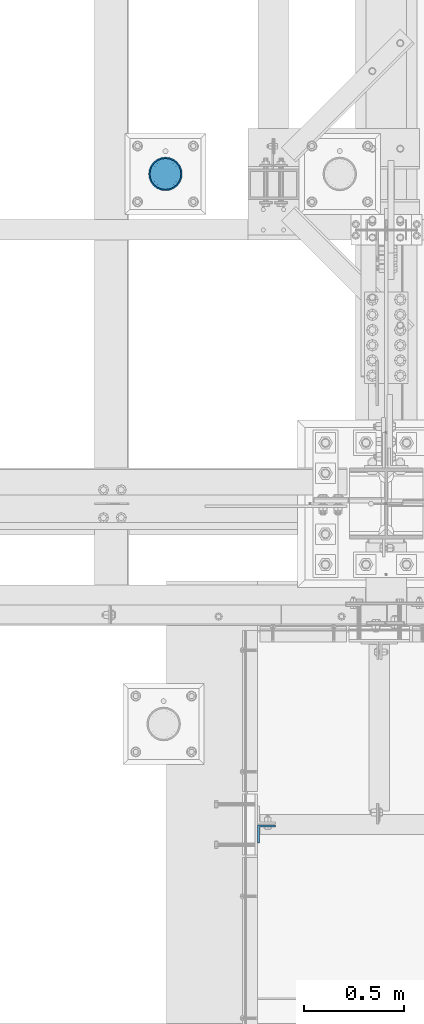
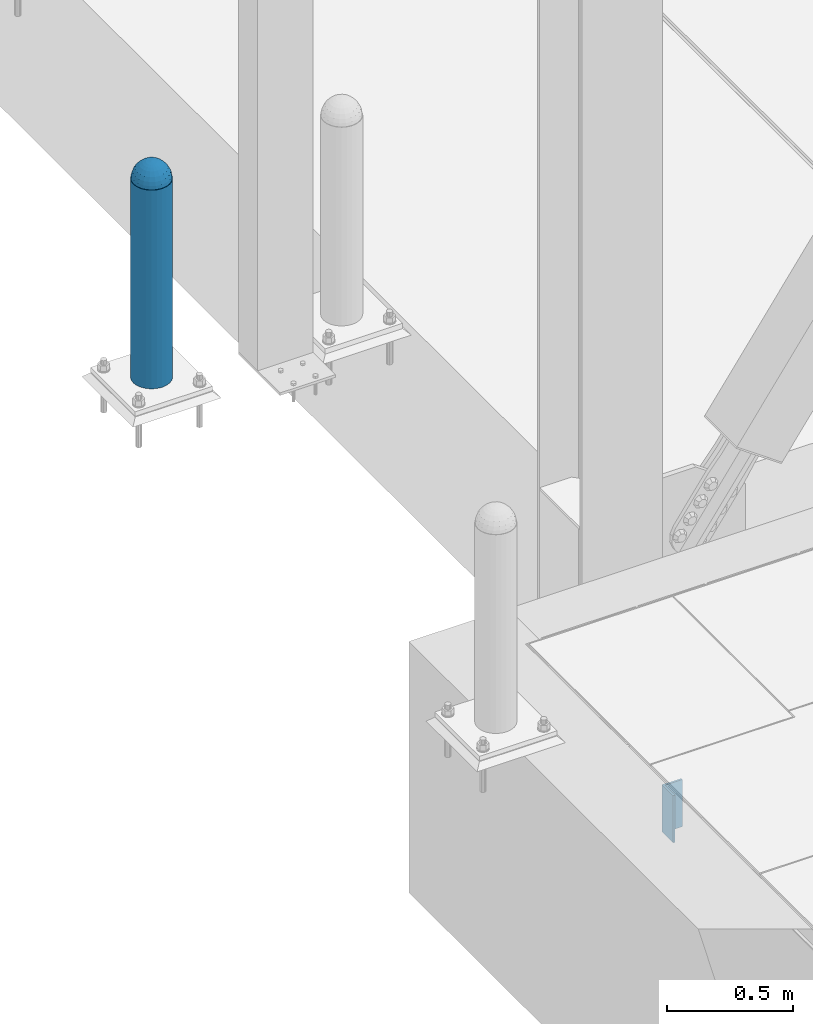
# One storey, part 1458 of 3843: 3 columns, 3 elements without a shape of their own.
"""IFC2X3 building model written with IfcOpenShell, lengths in millimetres."""

from ifc_helpers import new_model, si_unit, frame, origin_with_axes, place, context, subcontext, project, spatial, faceted_brep, material, type_object, element, aggregate, save


model = new_model("IFC2X3")

# Units and contexts
model_context = context("Model", 3, precision=1e-05, world=origin_with_axes())
body_context = subcontext(model_context, "Body", "Model", "MODEL_VIEW")
ifc_project = project(units=[si_unit("LENGTHUNIT", "METRE", prefix="MILLI"), si_unit("AREAUNIT", "SQUARE_METRE"), si_unit("VOLUMEUNIT", "CUBIC_METRE"), si_unit("MASSUNIT", "GRAM", prefix="KILO"), si_unit("TIMEUNIT", "SECOND"), si_unit("PLANEANGLEUNIT", "RADIAN"), si_unit("SOLIDANGLEUNIT", "STERADIAN"), si_unit("THERMODYNAMICTEMPERATUREUNIT", "DEGREE_CELSIUS"), si_unit("LUMINOUSINTENSITYUNIT", "LUMEN")], contexts=[model_context])

# Site, building, storey
site_placement = place(None, origin_with_axes())
site = spatial("IfcSite", under=ifc_project, at=site_placement, CompositionType="ELEMENT")
building_placement = place(site_placement, origin_with_axes())
building = spatial("IfcBuilding", under=site, at=building_placement, Name="Undefined", CompositionType="ELEMENT")
storey_placement = place(building_placement, origin_with_axes())
storey = spatial("IfcBuildingStorey", under=building, at=storey_placement, Name="Undefined", CompositionType="ELEMENT", Elevation=0.0)

# Assembly, column
assembly_1_placement = place(storey_placement, origin_with_axes())
assembly_1 = element("IfcElementAssembly", 1, at=assembly_1_placement, inside=storey, Name="CONC. FILL", AssemblyPlace="NOTDEFINED", PredefinedType="REINFORCEMENT_UNIT")
ifc_material_1 = material(Name="CONCRETE/1500")
column_type_1 = type_object("IfcColumnType", PredefinedType="NOTDEFINED")
column_1_placement = place(assembly_1_placement, frame((40956.2782592773, 27267.6153033043, 31411.8625), z_axis=(-1.0, 0.0, 0.0), x_axis=(0.0, 0.0, 1.0)))
column_1 = element("IfcColumn", 2, at=column_1_placement, type_object=column_type_1, material=ifc_material_1, Name="CONC. FILL", context=body_context, shape_type="Brep", body=[
    faceted_brep([(0.0, 0.0, 2.0), (0.0, -0.619999999995343, 1.89999999999964), (3.36549999999988, -7.1422259999963, 21.9814139999999), (3.36549999999988, 0.0, 23.1139999999996), (0.0, -1.17999999999302, 1.6200000000008), (3.36549999999988, -13.5910319999966, 18.6992260000006), (0.0, -1.61999999999534, 1.18000000000029), (3.36549999999988, -18.699225999997, 13.5910320000003), (0.0, -1.89999999999418, 0.6200000000008), (3.36549999999988, -21.9814139999944, 7.14222599999994), (0.0, -2.0, 0.0), (3.36549999999988, -23.1140000000014, 0.0), (0.0, -1.89999999999418, -0.6200000000008), (3.36549999999988, -21.9814139999944, -7.14222599999994), (0.0, -1.61999999999534, -1.18000000000029), (3.36549999999988, -18.699225999997, -13.5910320000003), (0.0, -1.17999999999302, -1.6200000000008), (3.36549999999988, -13.5910319999966, -18.6992260000006), (0.0, -0.619999999995343, -1.89999999999964), (3.36549999999988, -7.1422259999963, -21.9814139999999), (0.0, 0.0, -2.0), (3.36549999999988, 0.0, -23.1139999999996), (0.0, 0.619999999995343, -1.89999999999964), (3.36549999999988, 7.1422259999963, -21.9814139999999), (0.0, 1.17999999999302, -1.6200000000008), (3.36549999999988, 13.5910319999966, -18.6992260000006), (0.0, 1.61999999999534, -1.18000000000029), (3.36549999999988, 18.699225999997, -13.5910320000003), (0.0, 1.89999999999418, -0.6200000000008), (3.36549999999988, 21.9814139999944, -7.14222599999994), (0.0, 2.0, 0.0), (3.36549999999988, 23.1140000000014, 0.0), (0.0, 1.89999999999418, 0.6200000000008), (3.36549999999988, 21.9814139999944, 7.14222599999994), (0.0, 1.61999999999534, 1.18000000000029), (3.36549999999988, 18.699225999997, 13.5910320000003), (0.0, 1.17999999999302, 1.6200000000008), (3.36549999999988, 13.5910319999966, 18.6992260000006), (0.0, 0.619999999995343, 1.89999999999964), (3.36549999999988, 7.1422259999963, 21.9814139999999), (8.41374999999971, -11.1214661999984, 34.2282018000005), (8.41374999999971, 0.0, 35.9917999999998), (8.41374999999971, -21.1631784000056, 29.1173662000001), (8.41374999999971, -29.1173661999928, 21.1631784000001), (8.41374999999971, -34.2282017999969, 11.1214662000002), (8.41374999999971, -35.9918000000034, 0.0), (8.41374999999971, -34.2282017999969, -11.1214662000002), (8.41374999999971, -29.1173661999928, -21.1631784000001), (8.41374999999971, -21.1631784000056, -29.1173662000001), (8.41374999999971, -11.1214661999984, -34.2282018000005), (8.41374999999971, 0.0, -35.9917999999998), (8.41374999999971, 11.1214661999984, -34.2282018000005), (8.41374999999971, 21.1631784000056, -29.1173662000001), (8.41374999999971, 29.1173661999928, -21.1631784000001), (8.41374999999971, 34.2282017999969, -11.1214662000002), (8.41374999999971, 35.9918000000034, 0.0), (8.41374999999971, 34.2282017999969, 11.1214662000002), (8.41374999999971, 29.1173661999928, 21.1631784000001), (8.41374999999971, 21.1631784000056, 29.1173662000001), (8.41374999999971, 11.1214661999984, 34.2282018000005), (16.8274999999994, -15.3047700000025, 47.1030300000002), (16.8274999999994, 0.0, 49.5300000000007), (16.8274999999994, -29.1236400000053, 40.0697700000001), (16.8274999999994, -40.0697700000019, 29.1236399999998), (16.8274999999994, -47.1030299999984, 15.3047700000006), (16.8274999999994, -49.5299999999988, 0.0), (16.8274999999994, -47.1030299999984, -15.3047700000006), (16.8274999999994, -40.0697700000019, -29.1236399999998), (16.8274999999994, -29.1236400000053, -40.0697700000001), (16.8274999999994, -15.3047700000025, -47.1030300000002), (16.8274999999994, 0.0, -49.5300000000007), (16.8274999999994, 15.3047700000025, -47.1030300000002), (16.8274999999994, 29.1236400000053, -40.0697700000001), (16.8274999999994, 40.0697700000019, -29.1236399999998), (16.8274999999994, 47.1030299999984, -15.3047700000006), (16.8274999999994, 49.5299999999988, 0.0), (16.8274999999994, 47.1030299999984, 15.3047700000006), (16.8274999999994, 40.0697700000019, 29.1236399999998), (16.8274999999994, 29.1236400000053, 40.0697700000001), (16.8274999999994, 15.3047700000025, 47.1030300000002), (33.6549999999988, -20.4063599999936, 62.8040400000009), (33.6549999999988, 0.0, 66.0400000000009), (33.6549999999988, -38.831520000007, 53.4263599999995), (33.6549999999988, -53.4263599999977, 38.8315199999997), (33.6549999999988, -62.8040400000027, 20.4063600000009), (33.6549999999988, -66.0399999999936, 0.0), (33.6549999999988, -62.8040400000027, -20.4063600000009), (33.6549999999988, -53.4263599999977, -38.8315199999997), (33.6549999999988, -38.831520000007, -53.4263599999995), (33.6549999999988, -20.4063599999936, -62.8040400000009), (33.6549999999988, 0.0, -66.0400000000009), (33.6549999999988, 20.4063599999936, -62.8040400000009), (33.6549999999988, 38.831520000007, -53.4263599999995), (33.6549999999988, 53.4263599999977, -38.8315199999997), (33.6549999999988, 62.8040400000027, -20.4063600000009), (33.6549999999988, 66.0399999999936, 0.0), (33.6549999999988, 62.8040400000027, 20.4063600000009), (33.6549999999988, 53.4263599999977, 38.8315199999997), (33.6549999999988, 38.831520000007, 53.4263599999995), (33.6549999999988, 20.4063599999936, 62.8040400000009), (50.4824999999983, -23.3907901500061, 71.9891308499991), (50.4824999999983, 0.0, 75.6983500000006), (50.4824999999983, -44.5106298000028, 61.23996515), (50.4824999999983, -61.2399651500018, 44.5106297999992), (50.4824999999983, -71.9891308499937, 23.3907901500006), (50.4824999999983, -75.698350000006, 0.0), (50.4824999999983, -71.9891308499937, -23.3907901500006), (50.4824999999983, -61.2399651500018, -44.5106297999992), (50.4824999999983, -44.5106298000028, -61.23996515), (50.4824999999983, -23.3907901500061, -71.9891308499991), (50.4824999999983, 0.0, -75.6983500000006), (50.4824999999983, 23.3907901500061, -71.9891308499991), (50.4824999999983, 44.5106298000028, -61.23996515), (50.4824999999983, 61.2399651500018, -44.5106297999992), (50.4824999999983, 71.9891308499937, -23.3907901500006), (50.4824999999983, 75.698350000006, 0.0), (50.4824999999983, 71.9891308499937, 23.3907901500006), (50.4824999999983, 61.2399651500018, 44.5106297999992), (50.4824999999983, 44.5106298000028, 61.23996515), (50.4824999999983, 23.3907901500061, 71.9891308499991), (67.3099999999977, -24.9977910000016, 76.9349490000004), (67.3099999999977, 0.0, 80.8989999999994), (67.3099999999977, -47.5686120000028, 65.4472910000004), (67.3099999999977, -65.447291000004, 47.5686119999991), (67.3099999999977, -76.9349490000022, 24.9977909999998), (67.3099999999977, -80.8990000000049, 0.0), (67.3099999999977, -76.9349490000022, -24.9977909999998), (67.3099999999977, -65.447291000004, -47.5686119999991), (67.3099999999977, -47.5686120000028, -65.4472910000004), (67.3099999999977, -24.9977910000016, -76.9349490000004), (67.3099999999977, 0.0, -80.8989999999994), (67.3099999999977, 24.9977910000016, -76.9349490000004), (67.3099999999977, 47.5686120000028, -65.4472910000004), (67.3099999999977, 65.447291000004, -47.5686119999991), (67.3099999999977, 76.9349490000022, -24.9977909999998), (67.3099999999977, 80.8990000000049, 0.0), (67.3099999999977, 76.9349490000022, 24.9977909999998), (67.3099999999977, 65.447291000004, 47.5686119999991), (67.3099999999977, 47.5686120000028, 65.4472910000004), (67.3099999999977, 24.9977910000016, 76.9349490000004), (84.1374999999935, -25.5079499999993, 78.5050499999998), (84.1374999999935, 0.0, 82.5499999999993), (84.1374999999935, -48.5393999999942, 66.7829500000007), (84.1374999999935, -66.7829499999934, 48.5393999999997), (84.1374999999935, -78.505050000007, 25.5079499999993), (84.1374999999935, -82.5500000000029, 0.0), (84.1374999999935, -78.505050000007, -25.5079499999993), (84.1374999999935, -66.7829499999934, -48.5393999999997), (84.1374999999935, -48.5393999999942, -66.7829500000007), (84.1374999999935, -25.5079499999993, -78.5050499999998), (84.1374999999935, 0.0, -82.5499999999993), (84.1374999999935, 25.5079499999993, -78.5050499999998), (84.1374999999935, 48.5393999999942, -66.7829500000007), (84.1374999999935, 66.7829499999934, -48.5393999999997), (84.1374999999935, 78.505050000007, -25.5079499999993), (84.1374999999935, 82.5500000000029, 0.0), (84.1374999999935, 78.505050000007, 25.5079499999993), (84.1374999999935, 66.7829499999934, 48.5393999999997), (84.1374999999935, 48.5393999999942, 66.7829500000007), (84.1374999999935, 25.5079499999993, 78.5050499999998), (100.964999999993, -24.9977910000016, 76.9349490000004), (100.964999999993, 0.0, 80.8989999999994), (100.964999999993, -47.5686120000028, 65.4472910000004), (100.964999999993, -65.447291000004, 47.5686119999991), (100.964999999993, -76.9349490000022, 24.9977909999998), (100.964999999993, -80.8990000000049, 0.0), (100.964999999993, -76.9349490000022, -24.9977909999998), (100.964999999993, -65.447291000004, -47.5686119999991), (100.964999999993, -47.5686120000028, -65.4472910000004), (100.964999999993, -24.9977910000016, -76.9349490000004), (100.964999999993, 0.0, -80.8989999999994), (100.964999999993, 24.9977910000016, -76.9349490000004), (100.964999999993, 47.5686120000028, -65.4472910000004), (100.964999999993, 65.447291000004, -47.5686119999991), (100.964999999993, 76.9349490000022, -24.9977909999998), (100.964999999993, 80.8990000000049, 0.0), (100.964999999993, 76.9349490000022, 24.9977909999998), (100.964999999993, 65.447291000004, 47.5686119999991), (100.964999999993, 47.5686120000028, 65.4472910000004), (100.964999999993, 24.9977910000016, 76.9349490000004), (117.792499999992, -23.3907901500061, 71.9891308499991), (117.792499999992, 0.0, 75.6983500000006), (117.792499999992, -44.5106298000028, 61.23996515), (117.792499999992, -61.2399651500018, 44.5106297999992), (117.792499999992, -71.9891308499937, 23.3907901500006), (117.792499999992, -75.698350000006, 0.0), (117.792499999992, -71.9891308499937, -23.3907901500006), (117.792499999992, -61.2399651500018, -44.5106297999992), (117.792499999992, -44.5106298000028, -61.23996515), (117.792499999992, -23.3907901500061, -71.9891308499991), (117.792499999992, 0.0, -75.6983500000006), (117.792499999992, 23.3907901500061, -71.9891308499991), (117.792499999992, 44.5106298000028, -61.23996515), (117.792499999992, 61.2399651500018, -44.5106297999992), (117.792499999992, 71.9891308499937, -23.3907901500006), (117.792499999992, 75.698350000006, 0.0), (117.792499999992, 71.9891308499937, 23.3907901500006), (117.792499999992, 61.2399651500018, 44.5106297999992), (117.792499999992, 44.5106298000028, 61.23996515), (117.792499999992, 23.3907901500061, 71.9891308499991), (134.619999999992, -20.4063599999936, 62.8040400000009), (134.619999999992, 0.0, 66.0400000000009), (134.619999999992, -38.831520000007, 53.4263599999995), (134.619999999992, -53.4263599999977, 38.8315199999997), (134.619999999992, -62.8040400000027, 20.4063600000009), (134.619999999992, -66.0399999999936, 0.0), (134.619999999992, -62.8040400000027, -20.4063600000009), (134.619999999992, -53.4263599999977, -38.8315199999997), (134.619999999992, -38.831520000007, -53.4263599999995), (134.619999999992, -20.4063599999936, -62.8040400000009), (134.619999999992, 0.0, -66.0400000000009), (134.619999999992, 20.4063599999936, -62.8040400000009), (134.619999999992, 38.831520000007, -53.4263599999995), (134.619999999992, 53.4263599999977, -38.8315199999997), (134.619999999992, 62.8040400000027, -20.4063600000009), (134.619999999992, 66.0399999999936, 0.0), (134.619999999992, 62.8040400000027, 20.4063600000009), (134.619999999992, 53.4263599999977, 38.8315199999997), (134.619999999992, 38.831520000007, 53.4263599999995), (134.619999999992, 20.4063599999936, 62.8040400000009), (151.447499999991, -15.3047700000025, 47.1030300000002), (151.447499999991, 0.0, 49.5300000000007), (151.447499999991, -29.1236400000053, 40.0697700000001), (151.447499999991, -40.0697700000019, 29.1236399999998), (151.447499999991, -47.1030299999984, 15.3047700000006), (151.447499999991, -49.5299999999988, 0.0), (151.447499999991, -47.1030299999984, -15.3047700000006), (151.447499999991, -40.0697700000019, -29.1236399999998), (151.447499999991, -29.1236400000053, -40.0697700000001), (151.447499999991, -15.3047700000025, -47.1030300000002), (151.447499999991, 0.0, -49.5300000000007), (151.447499999991, 15.3047700000025, -47.1030300000002), (151.447499999991, 29.1236400000053, -40.0697700000001), (151.447499999991, 40.0697700000019, -29.1236399999998), (151.447499999991, 47.1030299999984, -15.3047700000006), (151.447499999991, 49.5299999999988, 0.0), (151.447499999991, 47.1030299999984, 15.3047700000006), (151.447499999991, 40.0697700000019, 29.1236399999998), (151.447499999991, 29.1236400000053, 40.0697700000001), (151.447499999991, 15.3047700000025, 47.1030300000002), (159.861249999991, -11.1214661999984, 34.2282018000005), (159.861249999991, 0.0, 35.9917999999998), (159.861249999991, -21.1631784000056, 29.1173662000001), (159.861249999991, -29.1173661999928, 21.1631784000001), (159.861249999991, -34.2282017999969, 11.1214662000002), (159.861249999991, -35.9918000000034, 0.0), (159.861249999991, -34.2282017999969, -11.1214662000002), (159.861249999991, -29.1173661999928, -21.1631784000001), (159.861249999991, -21.1631784000056, -29.1173662000001), (159.861249999991, -11.1214661999984, -34.2282018000005), (159.861249999991, 0.0, -35.9917999999998), (159.861249999991, 11.1214661999984, -34.2282018000005), (159.861249999991, 21.1631784000056, -29.1173662000001), (159.861249999991, 29.1173661999928, -21.1631784000001), (159.861249999991, 34.2282017999969, -11.1214662000002), (159.861249999991, 35.9918000000034, 0.0), (159.861249999991, 34.2282017999969, 11.1214662000002), (159.861249999991, 29.1173661999928, 21.1631784000001), (159.861249999991, 21.1631784000056, 29.1173662000001), (159.861249999991, 11.1214661999984, 34.2282018000005), (164.909499999991, -7.1422259999963, 21.9814139999999), (164.909499999991, 0.0, 23.1139999999996), (164.909499999991, -13.5910319999966, 18.6992260000006), (164.909499999991, -18.699225999997, 13.5910320000003), (164.909499999991, -21.9814139999944, 7.14222599999994), (164.909499999991, -23.1140000000014, 0.0), (164.909499999991, -21.9814139999944, -7.14222599999994), (164.909499999991, -18.699225999997, -13.5910320000003), (164.909499999991, -13.5910319999966, -18.6992260000006), (164.909499999991, -7.1422259999963, -21.9814139999999), (164.909499999991, 0.0, -23.1139999999996), (164.909499999991, 7.1422259999963, -21.9814139999999), (164.909499999991, 13.5910319999966, -18.6992260000006), (164.909499999991, 18.699225999997, -13.5910320000003), (164.909499999991, 21.9814139999944, -7.14222599999994), (164.909499999991, 23.1140000000014, 0.0), (164.909499999991, 21.9814139999944, 7.14222599999994), (164.909499999991, 18.699225999997, 13.5910320000003), (164.909499999991, 13.5910319999966, 18.6992260000006), (164.909499999991, 7.1422259999963, 21.9814139999999), (168.274999999991, -0.619999999995343, 1.89999999999964), (168.274999999991, 0.0, 2.0), (168.274999999991, -1.17999999999302, 1.6200000000008), (168.274999999991, -1.61999999999534, 1.18000000000029), (168.274999999991, -1.89999999999418, 0.6200000000008), (168.274999999991, -2.0, 0.0), (168.274999999991, -1.89999999999418, -0.6200000000008), (168.274999999991, -1.61999999999534, -1.18000000000029), (168.274999999991, -1.17999999999302, -1.6200000000008), (168.274999999991, -0.619999999995343, -1.89999999999964), (168.274999999991, 0.0, -2.0), (168.274999999991, 0.619999999995343, -1.89999999999964), (168.274999999991, 1.17999999999302, -1.6200000000008), (168.274999999991, 1.61999999999534, -1.18000000000029), (168.274999999991, 1.89999999999418, -0.6200000000008), (168.274999999991, 2.0, 0.0), (168.274999999991, 1.89999999999418, 0.6200000000008), (168.274999999991, 1.61999999999534, 1.18000000000029), (168.274999999991, 1.17999999999302, 1.6200000000008), (168.274999999991, 0.619999999995343, 1.89999999999964)], [[[0, 1, 2, 3]], [[1, 4, 5, 2]], [[4, 6, 7, 5]], [[6, 8, 9, 7]], [[8, 10, 11, 9]], [[10, 12, 13, 11]], [[12, 14, 15, 13]], [[14, 16, 17, 15]], [[16, 18, 19, 17]], [[18, 20, 21, 19]], [[20, 22, 23, 21]], [[22, 24, 25, 23]], [[24, 26, 27, 25]], [[26, 28, 29, 27]], [[28, 30, 31, 29]], [[30, 32, 33, 31]], [[32, 34, 35, 33]], [[34, 36, 37, 35]], [[36, 38, 39, 37]], [[38, 0, 3, 39]], [[38, 36, 34, 32, 30, 28, 26, 24, 22, 20, 18, 16, 14, 12, 10, 8, 6, 4, 1, 0]], [[3, 2, 40, 41]], [[2, 5, 42, 40]], [[5, 7, 43, 42]], [[7, 9, 44, 43]], [[9, 11, 45, 44]], [[11, 13, 46, 45]], [[13, 15, 47, 46]], [[15, 17, 48, 47]], [[17, 19, 49, 48]], [[19, 21, 50, 49]], [[21, 23, 51, 50]], [[23, 25, 52, 51]], [[25, 27, 53, 52]], [[27, 29, 54, 53]], [[29, 31, 55, 54]], [[31, 33, 56, 55]], [[33, 35, 57, 56]], [[35, 37, 58, 57]], [[37, 39, 59, 58]], [[39, 3, 41, 59]], [[41, 40, 60, 61]], [[40, 42, 62, 60]], [[42, 43, 63, 62]], [[43, 44, 64, 63]], [[44, 45, 65, 64]], [[45, 46, 66, 65]], [[46, 47, 67, 66]], [[47, 48, 68, 67]], [[48, 49, 69, 68]], [[49, 50, 70, 69]], [[50, 51, 71, 70]], [[51, 52, 72, 71]], [[52, 53, 73, 72]], [[53, 54, 74, 73]], [[54, 55, 75, 74]], [[55, 56, 76, 75]], [[56, 57, 77, 76]], [[57, 58, 78, 77]], [[58, 59, 79, 78]], [[59, 41, 61, 79]], [[61, 60, 80, 81]], [[60, 62, 82, 80]], [[62, 63, 83, 82]], [[63, 64, 84, 83]], [[64, 65, 85, 84]], [[65, 66, 86, 85]], [[66, 67, 87, 86]], [[67, 68, 88, 87]], [[68, 69, 89, 88]], [[69, 70, 90, 89]], [[70, 71, 91, 90]], [[71, 72, 92, 91]], [[72, 73, 93, 92]], [[73, 74, 94, 93]], [[74, 75, 95, 94]], [[75, 76, 96, 95]], [[76, 77, 97, 96]], [[77, 78, 98, 97]], [[78, 79, 99, 98]], [[79, 61, 81, 99]], [[81, 80, 100, 101]], [[80, 82, 102, 100]], [[82, 83, 103, 102]], [[83, 84, 104, 103]], [[84, 85, 105, 104]], [[85, 86, 106, 105]], [[86, 87, 107, 106]], [[87, 88, 108, 107]], [[88, 89, 109, 108]], [[89, 90, 110, 109]], [[90, 91, 111, 110]], [[91, 92, 112, 111]], [[92, 93, 113, 112]], [[93, 94, 114, 113]], [[94, 95, 115, 114]], [[95, 96, 116, 115]], [[96, 97, 117, 116]], [[97, 98, 118, 117]], [[98, 99, 119, 118]], [[99, 81, 101, 119]], [[101, 100, 120, 121]], [[100, 102, 122, 120]], [[102, 103, 123, 122]], [[103, 104, 124, 123]], [[104, 105, 125, 124]], [[105, 106, 126, 125]], [[106, 107, 127, 126]], [[107, 108, 128, 127]], [[108, 109, 129, 128]], [[109, 110, 130, 129]], [[110, 111, 131, 130]], [[111, 112, 132, 131]], [[112, 113, 133, 132]], [[113, 114, 134, 133]], [[114, 115, 135, 134]], [[115, 116, 136, 135]], [[116, 117, 137, 136]], [[117, 118, 138, 137]], [[118, 119, 139, 138]], [[119, 101, 121, 139]], [[121, 120, 140, 141]], [[120, 122, 142, 140]], [[122, 123, 143, 142]], [[123, 124, 144, 143]], [[124, 125, 145, 144]], [[125, 126, 146, 145]], [[126, 127, 147, 146]], [[127, 128, 148, 147]], [[128, 129, 149, 148]], [[129, 130, 150, 149]], [[130, 131, 151, 150]], [[131, 132, 152, 151]], [[132, 133, 153, 152]], [[133, 134, 154, 153]], [[134, 135, 155, 154]], [[135, 136, 156, 155]], [[136, 137, 157, 156]], [[137, 138, 158, 157]], [[138, 139, 159, 158]], [[139, 121, 141, 159]], [[141, 140, 160, 161]], [[140, 142, 162, 160]], [[142, 143, 163, 162]], [[143, 144, 164, 163]], [[144, 145, 165, 164]], [[145, 146, 166, 165]], [[146, 147, 167, 166]], [[147, 148, 168, 167]], [[148, 149, 169, 168]], [[149, 150, 170, 169]], [[150, 151, 171, 170]], [[151, 152, 172, 171]], [[152, 153, 173, 172]], [[153, 154, 174, 173]], [[154, 155, 175, 174]], [[155, 156, 176, 175]], [[156, 157, 177, 176]], [[157, 158, 178, 177]], [[158, 159, 179, 178]], [[159, 141, 161, 179]], [[161, 160, 180, 181]], [[160, 162, 182, 180]], [[162, 163, 183, 182]], [[163, 164, 184, 183]], [[164, 165, 185, 184]], [[165, 166, 186, 185]], [[166, 167, 187, 186]], [[167, 168, 188, 187]], [[168, 169, 189, 188]], [[169, 170, 190, 189]], [[170, 171, 191, 190]], [[171, 172, 192, 191]], [[172, 173, 193, 192]], [[173, 174, 194, 193]], [[174, 175, 195, 194]], [[175, 176, 196, 195]], [[176, 177, 197, 196]], [[177, 178, 198, 197]], [[178, 179, 199, 198]], [[179, 161, 181, 199]], [[181, 180, 200, 201]], [[180, 182, 202, 200]], [[182, 183, 203, 202]], [[183, 184, 204, 203]], [[184, 185, 205, 204]], [[185, 186, 206, 205]], [[186, 187, 207, 206]], [[187, 188, 208, 207]], [[188, 189, 209, 208]], [[189, 190, 210, 209]], [[190, 191, 211, 210]], [[191, 192, 212, 211]], [[192, 193, 213, 212]], [[193, 194, 214, 213]], [[194, 195, 215, 214]], [[195, 196, 216, 215]], [[196, 197, 217, 216]], [[197, 198, 218, 217]], [[198, 199, 219, 218]], [[199, 181, 201, 219]], [[201, 200, 220, 221]], [[200, 202, 222, 220]], [[202, 203, 223, 222]], [[203, 204, 224, 223]], [[204, 205, 225, 224]], [[205, 206, 226, 225]], [[206, 207, 227, 226]], [[207, 208, 228, 227]], [[208, 209, 229, 228]], [[209, 210, 230, 229]], [[210, 211, 231, 230]], [[211, 212, 232, 231]], [[212, 213, 233, 232]], [[213, 214, 234, 233]], [[214, 215, 235, 234]], [[215, 216, 236, 235]], [[216, 217, 237, 236]], [[217, 218, 238, 237]], [[218, 219, 239, 238]], [[219, 201, 221, 239]], [[221, 220, 240, 241]], [[220, 222, 242, 240]], [[222, 223, 243, 242]], [[223, 224, 244, 243]], [[224, 225, 245, 244]], [[225, 226, 246, 245]], [[226, 227, 247, 246]], [[227, 228, 248, 247]], [[228, 229, 249, 248]], [[229, 230, 250, 249]], [[230, 231, 251, 250]], [[231, 232, 252, 251]], [[232, 233, 253, 252]], [[233, 234, 254, 253]], [[234, 235, 255, 254]], [[235, 236, 256, 255]], [[236, 237, 257, 256]], [[237, 238, 258, 257]], [[238, 239, 259, 258]], [[239, 221, 241, 259]], [[241, 240, 260, 261]], [[240, 242, 262, 260]], [[242, 243, 263, 262]], [[243, 244, 264, 263]], [[244, 245, 265, 264]], [[245, 246, 266, 265]], [[246, 247, 267, 266]], [[247, 248, 268, 267]], [[248, 249, 269, 268]], [[249, 250, 270, 269]], [[250, 251, 271, 270]], [[251, 252, 272, 271]], [[252, 253, 273, 272]], [[253, 254, 274, 273]], [[254, 255, 275, 274]], [[255, 256, 276, 275]], [[256, 257, 277, 276]], [[257, 258, 278, 277]], [[258, 259, 279, 278]], [[259, 241, 261, 279]], [[261, 260, 280, 281]], [[260, 262, 282, 280]], [[262, 263, 283, 282]], [[263, 264, 284, 283]], [[264, 265, 285, 284]], [[265, 266, 286, 285]], [[266, 267, 287, 286]], [[267, 268, 288, 287]], [[268, 269, 289, 288]], [[269, 270, 290, 289]], [[270, 271, 291, 290]], [[271, 272, 292, 291]], [[272, 273, 293, 292]], [[273, 274, 294, 293]], [[274, 275, 295, 294]], [[275, 276, 296, 295]], [[276, 277, 297, 296]], [[277, 278, 298, 297]], [[278, 279, 299, 298]], [[279, 261, 281, 299]], [[282, 283, 284, 285, 286, 287, 288, 289, 290, 291, 292, 293, 294, 295, 296, 297, 298, 299, 281, 280]]]),
])
aggregate(assembly_1, [column_1])

assembly_2_placement = place(storey_placement, origin_with_axes())
assembly_2 = element("IfcElementAssembly", 3, at=assembly_2_placement, inside=storey, Name="PIPE_BOLLARD", AssemblyPlace="NOTDEFINED", PredefinedType="RIGID_FRAME")
ifc_material_2 = material()
column_type_2 = type_object("IfcColumnType", Name="PIPE6SCH40", PredefinedType="NOTDEFINED")
column_2_placement = place(assembly_2_placement, frame((40956.2782592774, 27267.6153033043, 30480.0), z_axis=(-1.0, 0.0, 0.0), x_axis=(0.0, 0.0, 1.0)))
column_2 = element("IfcColumn", 4, at=column_2_placement, type_object=column_type_2, material=ifc_material_2, Name="PIPE_BOLLARD", ObjectType="PIPE6SCH40", context=body_context, shape_type="Brep", body=[
    faceted_brep([(50.7999999999993, -77.0890000000072, 0.0), (50.7999999999993, -74.4622560228017, 19.9521013679114), (1016.0, -74.4622560228017, 19.9521013679114), (1016.0, -77.0890000000072, 0.0), (50.7999999999993, -66.7610323523404, 38.5445000000036), (1016.0, -66.7610323523404, 38.5445000000036), (50.7999999999993, -54.5101546548831, 54.5101546548904), (1016.0, -54.5101546548831, 54.5101546548904), (50.7999999999993, -38.5445000000036, 66.7610323523404), (1016.0, -38.5445000000036, 66.7610323523404), (50.7999999999993, -19.9521013679041, 74.4622560227945), (1016.0, -19.9521013679041, 74.4622560227945), (50.7999999999993, 0.0, 77.0889999999999), (1016.0, 0.0, 77.0889999999999), (50.7999999999993, 19.9521013679041, 74.4622560227945), (1016.0, 19.9521013679041, 74.4622560227945), (50.7999999999993, 38.5445000000036, 66.7610323523404), (1016.0, 38.5445000000036, 66.7610323523404), (50.7999999999993, 54.5101546548831, 54.5101546548904), (1016.0, 54.5101546548831, 54.5101546548904), (50.7999999999993, 66.7610323523404, 38.5445000000036), (1016.0, 66.7610323523404, 38.5445000000036), (50.7999999999993, 74.4622560228017, 19.9521013679114), (1016.0, 74.4622560228017, 19.9521013679114), (50.7999999999993, 77.0890000000072, 0.0), (1016.0, 77.0890000000072, 0.0), (50.7999999999993, 74.4622560228017, -19.9521013679114), (1016.0, 74.4622560228017, -19.9521013679114), (50.7999999999993, 66.7610323523404, -38.5445000000036), (1016.0, 66.7610323523404, -38.5445000000036), (50.7999999999993, 54.5101546548831, -54.5101546548904), (1016.0, 54.5101546548831, -54.5101546548904), (50.7999999999993, 38.5445000000036, -66.7610323523404), (1016.0, 38.5445000000036, -66.7610323523404), (50.7999999999993, 19.9521013679041, -74.4622560227945), (1016.0, 19.9521013679041, -74.4622560227945), (50.7999999999993, 0.0, -77.0889999999999), (1016.0, 0.0, -77.0889999999999), (50.7999999999993, -19.9521013679041, -74.4622560227945), (1016.0, -19.9521013679041, -74.4622560227945), (50.7999999999993, -38.5445000000036, -66.7610323523404), (1016.0, -38.5445000000036, -66.7610323523404), (50.7999999999993, -54.5101546548831, -54.5101546548904), (1016.0, -54.5101546548831, -54.5101546548904), (50.7999999999993, -66.7610323523404, -38.5445000000036), (1016.0, -66.7610323523404, -38.5445000000036), (50.7999999999993, -74.4622560228017, -19.9521013679114), (1016.0, -74.4622560228017, -19.9521013679114), (50.7999999999993, -84.2010000000009, 0.0), (50.7999999999993, -81.3319204993604, -21.7928224166753), (1016.0, -81.3319204993604, -21.7928224166753), (1016.0, -84.2010000000009, 0.0), (50.7999999999993, -72.9202050240565, -42.1005000000005), (1016.0, -72.9202050240565, -42.1005000000005), (50.7999999999993, -59.5390980826924, -59.5390980826851), (1016.0, -59.5390980826924, -59.5390980826851), (50.7999999999993, -42.1005000000005, -72.9202050240565), (1016.0, -42.1005000000005, -72.9202050240565), (50.7999999999993, -21.7928224166826, -81.3319204993677), (1016.0, -21.7928224166826, -81.3319204993677), (50.7999999999993, 0.0, -84.2010000000009), (1016.0, 0.0, -84.2010000000009), (50.7999999999993, 21.7928224166826, -81.3319204993677), (1016.0, 21.7928224166826, -81.3319204993677), (50.7999999999993, 42.1005000000005, -72.9202050240565), (1016.0, 42.1005000000005, -72.9202050240565), (50.7999999999993, 59.5390980826924, -59.5390980826851), (1016.0, 59.5390980826924, -59.5390980826851), (50.7999999999993, 72.9202050240565, -42.1005000000005), (1016.0, 72.9202050240565, -42.1005000000005), (50.7999999999993, 81.3319204993604, -21.7928224166753), (1016.0, 81.3319204993604, -21.7928224166753), (50.7999999999993, 84.2010000000009, 0.0), (1016.0, 84.2010000000009, 0.0), (50.7999999999993, 81.3319204993604, 21.7928224166753), (1016.0, 81.3319204993604, 21.7928224166753), (50.7999999999993, 72.9202050240565, 42.1005000000005), (1016.0, 72.9202050240565, 42.1005000000005), (50.7999999999993, 59.5390980826924, 59.5390980826851), (1016.0, 59.5390980826924, 59.5390980826851), (50.7999999999993, 42.1005000000005, 72.9202050240565), (1016.0, 42.1005000000005, 72.9202050240565), (50.7999999999993, 21.7928224166826, 81.3319204993677), (1016.0, 21.7928224166826, 81.3319204993677), (50.7999999999993, 0.0, 84.2010000000009), (1016.0, 0.0, 84.2010000000009), (50.7999999999993, -21.7928224166826, 81.3319204993677), (1016.0, -21.7928224166826, 81.3319204993677), (50.7999999999993, -42.1005000000005, 72.9202050240565), (1016.0, -42.1005000000005, 72.9202050240565), (50.7999999999993, -59.5390980826924, 59.5390980826851), (1016.0, -59.5390980826924, 59.5390980826851), (50.7999999999993, -72.9202050240565, 42.1005000000005), (1016.0, -72.9202050240565, 42.1005000000005), (50.7999999999993, -81.3319204993604, 21.7928224166753), (1016.0, -81.3319204993604, 21.7928224166753)], [[[0, 1, 2, 3]], [[1, 4, 5, 2]], [[4, 6, 7, 5]], [[6, 8, 9, 7]], [[8, 10, 11, 9]], [[10, 12, 13, 11]], [[12, 14, 15, 13]], [[14, 16, 17, 15]], [[16, 18, 19, 17]], [[18, 20, 21, 19]], [[20, 22, 23, 21]], [[22, 24, 25, 23]], [[24, 26, 27, 25]], [[26, 28, 29, 27]], [[28, 30, 31, 29]], [[30, 32, 33, 31]], [[32, 34, 35, 33]], [[34, 36, 37, 35]], [[36, 38, 39, 37]], [[38, 40, 41, 39]], [[40, 42, 43, 41]], [[42, 44, 45, 43]], [[44, 46, 47, 45]], [[46, 0, 3, 47]], [[48, 49, 50, 51]], [[49, 52, 53, 50]], [[52, 54, 55, 53]], [[54, 56, 57, 55]], [[56, 58, 59, 57]], [[58, 60, 61, 59]], [[60, 62, 63, 61]], [[62, 64, 65, 63]], [[64, 66, 67, 65]], [[66, 68, 69, 67]], [[68, 70, 71, 69]], [[70, 72, 73, 71]], [[72, 74, 75, 73]], [[74, 76, 77, 75]], [[76, 78, 79, 77]], [[78, 80, 81, 79]], [[80, 82, 83, 81]], [[82, 84, 85, 83]], [[84, 86, 87, 85]], [[86, 88, 89, 87]], [[88, 90, 91, 89]], [[90, 92, 93, 91]], [[92, 94, 95, 93]], [[94, 48, 51, 95]], [[53, 55, 57, 59, 61, 63, 65, 67, 69, 71, 73, 75, 77, 79, 81, 83, 85, 87, 89, 91, 93, 95, 51, 50], [5, 7, 9, 11, 13, 15, 17, 19, 21, 23, 25, 27, 29, 31, 33, 35, 37, 39, 41, 43, 45, 47, 3, 2]], [[94, 92, 90, 88, 86, 84, 82, 80, 78, 76, 74, 72, 70, 68, 66, 64, 62, 60, 58, 56, 54, 52, 49, 48], [46, 44, 42, 40, 38, 36, 34, 32, 30, 28, 26, 24, 22, 20, 18, 16, 14, 12, 10, 8, 6, 4, 1, 0]]]),
])
aggregate(assembly_2, [column_2])

assembly_3_placement = place(storey_placement, origin_with_axes())
assembly_3 = element("IfcElementAssembly", 5, at=assembly_3_placement, inside=storey, Name="BEAM", AssemblyPlace="NOTDEFINED", PredefinedType="RIGID_FRAME")
ifc_material_3 = material(Name="STEEL/A36")
column_type_3 = type_object("IfcColumnType", Name="L3-1/2X3-1/2X3/8", PredefinedType="NOTDEFINED")
column_3_placement = place(assembly_3_placement, frame((41462.325, 23961.725, 30137.1), z_axis=(0.0, -1.0, 0.0), x_axis=(0.0, 0.0, 1.0)))
column_3 = element("IfcColumn", 6, at=column_3_placement, type_object=column_type_3, material=ifc_material_3, Name="ANGLE", ObjectType="L3-1/2X3-1/2X3/8", context=body_context, shape_type="Brep", body=[
    faceted_brep([(-3.63797880709171e-12, 44.4499999999971, -44.4500000000007), (-3.63797880709171e-12, 44.4499999999971, 44.4500000000007), (228.600000000006, 44.4499999999971, 44.4500000000007), (228.600000000006, 44.4499999999971, -44.4500000000007), (0.0, 34.9250000000029, 44.4500000000007), (228.600000000006, 34.9250000000029, 44.4500000000007), (0.0, 34.9250000000029, -34.9250000000029), (228.600000000006, 34.9250000000029, -34.9249999999993), (0.0, -44.4499999999971, -34.9249999999993), (228.600000000006, -44.4499999999971, -34.9249999999993), (3.63797880709171e-12, -44.4499999999971, -44.4500000000007), (228.600000000006, -44.4499999999971, -44.4500000000007)], [[[0, 1, 2, 3]], [[1, 4, 5, 2]], [[4, 6, 7, 5]], [[6, 8, 9, 7]], [[8, 10, 11, 9]], [[10, 0, 3, 11]], [[5, 7, 9, 11, 3, 2]], [[10, 8, 6, 4, 1, 0]]]),
])
aggregate(assembly_3, [column_3])

save(model, "model.ifc")
